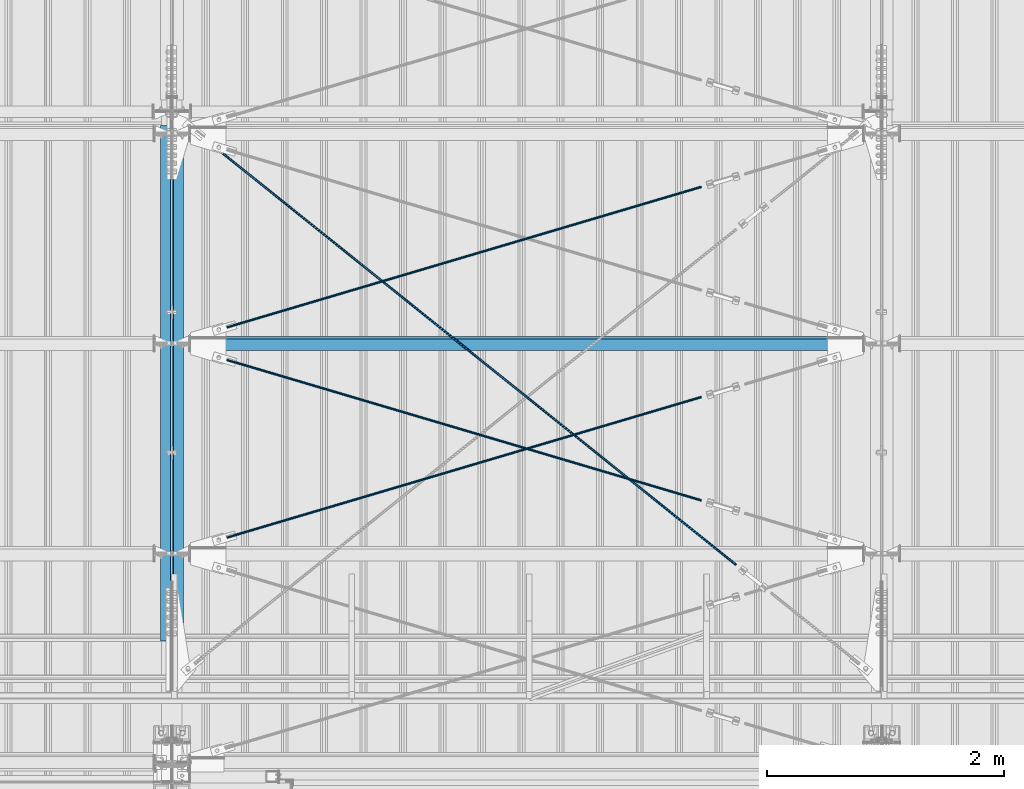
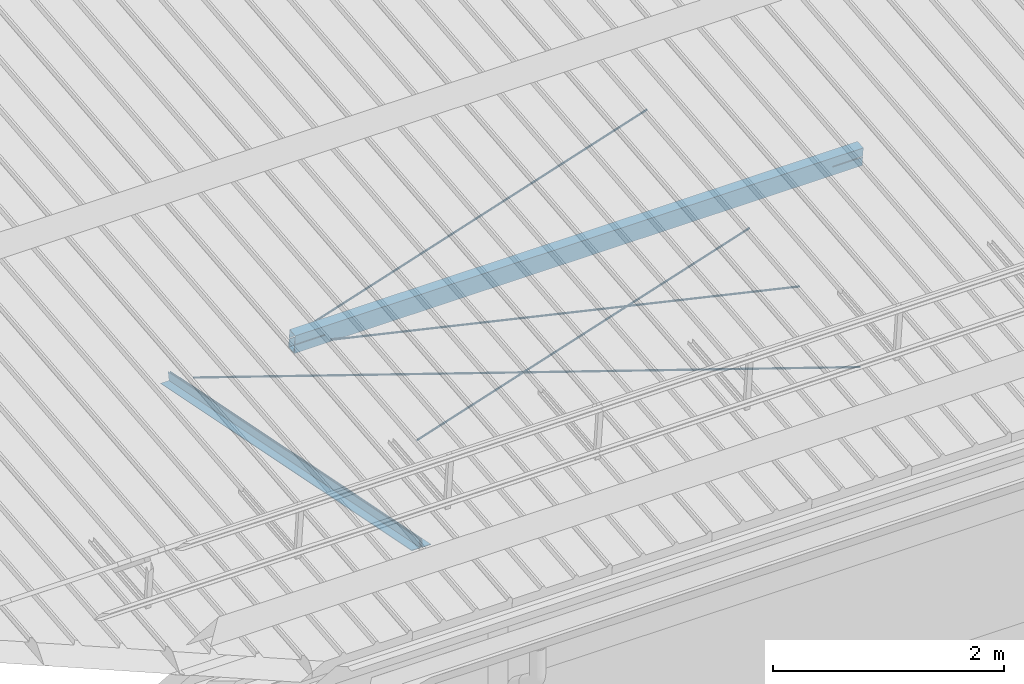
# One storey, part 274 of 709: 7 beams, 6 openings, 7 elements without a shape of their own.
"""IFC4 building model written with IfcOpenShell, lengths in millimetres."""

from ifc_helpers import new_model, si_unit, direction, frame, origin_with_axes, place, context, subcontext, project, spatial, line, indexed_curve, outline, extrude, polygons, material, element, aggregate, save


model = new_model("IFC4")

# Units and contexts
model_context = context("Model", 3, precision=0.2, world=origin_with_axes(), true_north=direction((0.0, 1.0)))
body_context = subcontext(model_context, "Body", "Model", "MODEL_VIEW")
reference_context = subcontext(model_context, "Reference", "Model", "MODEL_VIEW")
ifc_project = project(units=[si_unit("LENGTHUNIT", "METRE", prefix="MILLI"), si_unit("AREAUNIT", "SQUARE_METRE"), si_unit("VOLUMEUNIT", "CUBIC_METRE"), si_unit("MASSUNIT", "GRAM", prefix="KILO"), si_unit("TIMEUNIT", "SECOND"), si_unit("PLANEANGLEUNIT", "RADIAN"), si_unit("SOLIDANGLEUNIT", "STERADIAN"), si_unit("THERMODYNAMICTEMPERATUREUNIT", "DEGREE_CELSIUS"), si_unit("LUMINOUSINTENSITYUNIT", "LUMEN")], contexts=[model_context])

# Site, building, storey
site_placement = place(None, origin_with_axes())
site = spatial("IfcSite", under=ifc_project, at=site_placement, CompositionType="ELEMENT")
building_placement = place(site_placement, origin_with_axes())
building = spatial("IfcBuilding", under=site, at=building_placement, Name="Undefined", CompositionType="ELEMENT")
storey_placement = place(building_placement, origin_with_axes())
storey = spatial("IfcBuildingStorey", under=building, at=storey_placement, Name="Undefined", CompositionType="ELEMENT", Elevation=0.0)

# Assembly, beam
assembly_1_placement = place(storey_placement, frame((39949.0, 350.0596, 7109.99804), z_axis=(0.0, 0.1961161349, 0.9805806757), x_axis=(0.0, 0.9805806757, -0.1961161349)))
assembly_1 = element("IfcElementAssembly", 1, at=assembly_1_placement, inside=storey)
ifc_material_1 = material(Name="C345-5", Category="STEEL")
beam_1_placement = place(assembly_1_placement, origin_with_axes())
beam_1 = element("IfcBeam", 2, at=beam_1_placement, material=ifc_material_1, ObjectType="435", context=body_context, shape_type="Tessellation", body=[
    polygons([(873.96605, -45.0, -45.0), (873.96605, 45.0, -45.0), (5317.375, 45.0, -45.0), (5317.375, -45.0, -45.0), (873.96605, 45.0, -39.0), (5317.375, 45.0, -39.0), (873.96605, -39.0, -39.0), (5317.375, -39.0, -39.0), (873.96605, -39.0, 45.0), (5317.375, -39.0, 45.0), (873.96605, -45.0, 45.0), (5317.375, -45.0, 45.0)], [[[1, 2, 3, 4]], [[2, 5, 6, 3]], [[5, 7, 8, 6]], [[7, 9, 10, 8]], [[9, 11, 12, 10]], [[11, 1, 4, 12]], [[6, 8, 10, 12, 4, 3]], [[11, 9, 7, 5, 2, 1]]], closed=True),
])
aggregate(assembly_1, [beam_1])

assembly_2_placement = place(storey_placement, frame((40051.0, 5677.0596, 6044.59804), z_axis=(0.0, 0.1961161349, 0.9805806757), x_axis=(0.0, -0.9805806757, 0.1961161349)))
assembly_2 = element("IfcElementAssembly", 3, at=assembly_2_placement, inside=storey)
beam_2_placement = place(assembly_2_placement, origin_with_axes())
beam_2 = element("IfcBeam", 4, at=beam_2_placement, material=ifc_material_1, ObjectType="435", context=body_context, shape_type="Tessellation", body=[
    polygons([(115.12039, -45.0, -45.0), (115.12039, 45.0, -45.0), (4558.52934, 45.0, -45.0), (4558.52934, -45.0, -45.0), (115.12039, 45.0, -39.0), (4558.52934, 45.0, -39.0), (115.12039, -39.0, -39.0), (4558.52934, -39.0, -39.0), (115.12039, -39.0, 45.0), (4558.52934, -39.0, 45.0), (115.12039, -45.0, 45.0), (4558.52934, -45.0, 45.0)], [[[1, 2, 3, 4]], [[2, 5, 6, 3]], [[5, 7, 8, 6]], [[7, 9, 10, 8]], [[9, 11, 12, 10]], [[11, 1, 4, 12]], [[6, 8, 10, 12, 4, 3]], [[11, 9, 7, 5, 2, 1]]], closed=True),
])
aggregate(assembly_2, [beam_2])

# Assembly, beam, voiding feature
assembly_3_placement = place(storey_placement, frame((40000.0, 5665.09652, 5984.78262), z_axis=(-0.625451877, -0.7802627439, 1e-10), x_axis=(0.7742288439, -0.6206151549, 0.124123031)))
assembly_3 = element("IfcElementAssembly", 5, at=assembly_3_placement, inside=storey)
ifc_material_2 = material(Name="C355-5", Category="STEEL")
beam_3_placement = place(assembly_3_placement, origin_with_axes())
beam_3 = element("IfcBeam", 6, at=beam_3_placement, material=ifc_material_2, ObjectType="480", context=body_context, shape_type="Tessellation", body=[
    polygons([(6339.64669, 7.36121, 4.25), (6339.64669, 6.01041, 6.0104), (6339.64669, 4.25, 7.36121), (6339.64669, 2.19996, 8.21037), (6339.64669, 0.0, 8.5), (6339.64669, -2.19996, 8.21037), (6339.64669, -4.25, 7.36121), (6339.64669, -6.01041, 6.0104), (6339.64669, -7.36122, 4.25), (6339.64669, -8.21037, 2.19996), (6339.64669, -8.5, 0.0), (6339.64669, -8.21037, -2.19996), (6339.64669, -7.36122, -4.25), (6339.64669, -6.01041, -6.01041), (6339.64669, -4.25, -7.36122), (6339.64669, -2.19996, -8.21037), (6339.64669, 0.0, -8.5), (6339.64669, 2.19996, -8.21037), (6339.64669, 4.25, -7.36122), (6339.64669, 6.01041, -6.01041), (6339.64669, 7.36121, -4.25), (6339.64669, 8.21037, -2.19996), (6339.64669, 8.5, 0.0), (6339.64669, 8.21037, 2.19996), (6159.64669, 8.21037, 2.19996), (6159.64669, 7.36121, 4.25), (6159.64669, 6.01041, 6.0104), (6159.64669, 4.25, 7.36121), (6159.64669, 2.19996, 8.21037), (6159.64669, 0.0, 8.5), (6159.64669, -2.19996, 8.21037), (6159.64669, -4.25, 7.36121), (6159.64669, -6.01041, 6.0104), (6159.64669, -7.36122, 4.25), (6159.64669, -8.21037, 2.19996), (6159.64669, -8.5, 0.0), (6159.64669, -8.21037, -2.19996), (6159.64669, -7.36122, -4.25), (6159.64669, -6.01041, -6.01041), (6159.64669, -4.25, -7.36122), (6159.64669, -2.19996, -8.21037), (6159.64669, 0.0, -8.5), (6159.64669, 2.19996, -8.21037), (6159.64669, 4.25, -7.36122), (6159.64669, 6.01041, -6.01041), (6159.64669, 7.36121, -4.25), (6159.64669, 8.21037, -2.19996), (6159.64669, 8.5, 0.0), (6159.64669, 10.0, 0.0), (6159.64669, 9.65926, 2.58819), (6159.64669, 8.66025, 5.0), (6159.64669, 7.07107, 7.07107), (6159.64669, 5.0, 8.66025), (6159.64669, 2.58819, 9.65926), (6159.64669, 0.0, 10.0), (6159.64669, -2.58819, 9.65926), (6159.64669, -5.0, 8.66025), (6159.64669, -7.07107, 7.07107), (6159.64669, -8.66025, 5.0), (6159.64669, -9.65926, 2.58819), (6159.64669, -10.0, 0.0), (6159.64669, -9.65926, -2.58819), (6159.64669, -8.66025, -5.0), (6159.64669, -7.07107, -7.07107), (6159.64669, -5.0, -8.66025), (6159.64669, -2.58819, -9.65926), (6159.64669, 0.0, -10.0), (6159.64669, 2.58819, -9.65926), (6159.64669, 5.0, -8.66025), (6159.64669, 7.07107, -7.07107), (6159.64669, 8.66025, -5.0), (6159.64669, 9.65926, -2.58819), (259.57474, 2.58819, 9.65926), (259.57474, 5.0, 8.66025), (259.57474, 7.07107, 7.07107), (259.57474, 8.66025, 5.0), (259.57474, 9.65926, 2.58819), (259.57474, 10.0, 0.0), (259.57474, 9.65926, -2.58819), (259.57474, 8.66025, -5.0), (259.57474, 7.07107, -7.07107), (259.57474, 5.0, -8.66025), (259.57474, 2.58819, -9.65926), (259.57474, 0.0, -10.0), (259.57474, -2.58819, -9.65926), (259.57474, -5.0, -8.66025), (259.57474, -7.07107, -7.07107), (259.57474, -8.66025, -5.0), (259.57474, -9.65926, -2.58819), (259.57474, -10.0, 0.0), (259.57474, -9.65926, 2.58819), (259.57474, -8.66025, 5.0), (259.57474, -7.07107, 7.07107), (259.57474, -5.0, 8.66025), (259.57474, -2.58819, 9.65926), (259.57474, 0.0, 10.0)], [[[1, 2, 3, 4, 5, 6, 7, 8, 9, 10, 11, 12, 13, 14, 15, 16, 17, 18, 19, 20, 21, 22, 23, 24]], [[24, 25, 26, 1]], [[1, 26, 27, 2]], [[2, 27, 28, 3]], [[3, 28, 29, 4]], [[4, 29, 30, 5]], [[5, 30, 31, 6]], [[6, 31, 32, 7]], [[7, 32, 33, 8]], [[8, 33, 34, 9]], [[9, 34, 35, 10]], [[10, 35, 36, 11]], [[11, 36, 37, 12]], [[12, 37, 38, 13]], [[13, 38, 39, 14]], [[14, 39, 40, 15]], [[15, 40, 41, 16]], [[16, 41, 42, 17]], [[17, 42, 43, 18]], [[18, 43, 44, 19]], [[19, 44, 45, 20]], [[20, 45, 46, 21]], [[21, 46, 47, 22]], [[22, 47, 48, 23]], [[23, 48, 25, 24]], [[49, 50, 51, 52, 53, 54, 55, 56, 57, 58, 59, 60, 61, 62, 63, 64, 65, 66, 67, 68, 69, 70, 71, 72], [47, 46, 45, 44, 43, 42, 41, 40, 39, 38, 37, 36, 35, 34, 33, 32, 31, 30, 29, 28, 27, 26, 25, 48]], [[73, 74, 75, 76, 77, 78, 79, 80, 81, 82, 83, 84, 85, 86, 87, 88, 89, 90, 91, 92, 93, 94, 95, 96]], [[79, 78, 49, 72]], [[80, 79, 72, 71]], [[81, 80, 71, 70]], [[82, 81, 70, 69]], [[83, 82, 69, 68]], [[84, 83, 68, 67]], [[85, 84, 67, 66]], [[86, 85, 66, 65]], [[87, 86, 65, 64]], [[88, 87, 64, 63]], [[89, 88, 63, 62]], [[90, 89, 62, 61]], [[91, 90, 61, 60]], [[92, 91, 60, 59]], [[93, 92, 59, 58]], [[94, 93, 58, 57]], [[95, 94, 57, 56]], [[96, 95, 56, 55]], [[73, 96, 55, 54]], [[74, 73, 54, 53]], [[75, 74, 53, 52]], [[76, 75, 52, 51]], [[77, 76, 51, 50]], [[78, 77, 50, 49]]], closed=True),
])
voiding_feature_1_placement = place(beam_3_placement, frame((6339.64669, 0.0, 0.0), z_axis=(0.0, 1.0, 0.0), x_axis=(-1.0, 0.0, 0.0)))
element("IfcVoidingFeature", 7, at=voiding_feature_1_placement, cuts=beam_3, PredefinedType="HOLE", context=reference_context, identifier="Reference", shape_type="SolidModel", body=[
    extrude(outline(indexed_curve([(10.5, 0.0), (10.14222, 2.7176), (9.09327, 5.25), (7.42462, 7.42462), (5.25, 9.09327), (2.7176, 10.14222), (0.0, 10.5), (-2.7176, 10.14222), (-5.25, 9.09327), (-7.42462, 7.42462), (-9.09327, 5.25), (-10.14222, 2.7176), (-10.5, 0.0), (-10.14222, -2.7176), (-9.09327, -5.25), (-7.42462, -7.42462), (-5.25, -9.09327), (-2.7176, -10.14222), (0.0, -10.5), (2.7176, -10.14222), (5.25, -9.09327), (7.42462, -7.42462), (9.09327, -5.25), (10.14222, -2.7176)], segments=[line(1, 2, 3, 4, 5, 6, 7, 8, 9, 10, 11, 12, 13, 14, 15, 16, 17, 18, 19, 20, 21, 22, 23, 24, 1)])), frame((0.0, 0.0, 0.0), z_axis=(-1.0, 0.0, 0.0), x_axis=(0.0, 0.0, 1.0)), (0.0, 0.0, -1.0), 180.0),
])
aggregate(assembly_3, [beam_3])

assembly_4_placement = place(storey_placement, frame((40000.0, 1935.85409, 7330.08943), z_axis=(0.2852311229, -0.9537021177, -0.0953702118), x_axis=(0.9584587662, 0.2838155751, 0.028381558)))
assembly_4 = element("IfcElementAssembly", 8, at=assembly_4_placement, inside=storey)
beam_4_placement = place(assembly_4_placement, origin_with_axes())
beam_4 = element("IfcBeam", 9, at=beam_4_placement, material=ifc_material_2, ObjectType="570", context=body_context, shape_type="Tessellation", body=[
    polygons([(4850.05021, 7.36122, 4.25), (4850.05021, 6.01041, 6.01041), (4850.05021, 4.25, 7.36121), (4850.05021, 2.19996, 8.21037), (4850.05021, 0.0, 8.5), (4850.05021, -2.19996, 8.21037), (4850.05021, -4.25, 7.36121), (4850.05021, -6.01041, 6.01041), (4850.05021, -7.36121, 4.25), (4850.05021, -8.21037, 2.19996), (4850.05021, -8.5, 0.0), (4850.05021, -8.21037, -2.19996), (4850.05021, -7.36121, -4.25), (4850.05021, -6.01041, -6.01041), (4850.05021, -4.25, -7.36122), (4850.05021, -2.19996, -8.21037), (4850.05021, 0.0, -8.5), (4850.05021, 2.19996, -8.21037), (4850.05021, 4.25, -7.36122), (4850.05021, 6.01041, -6.01041), (4850.05021, 7.36122, -4.25), (4850.05021, 8.21037, -2.19996), (4850.05021, 8.5, 0.0), (4850.05021, 8.21037, 2.19996), (4670.05021, 8.21037, 2.19996), (4670.05021, 7.36122, 4.25), (4670.05021, 6.01041, 6.01041), (4670.05021, 4.25, 7.36121), (4670.05021, 2.19996, 8.21037), (4670.05021, 0.0, 8.5), (4670.05021, -2.19996, 8.21037), (4670.05021, -4.25, 7.36121), (4670.05021, -6.01041, 6.01041), (4670.05021, -7.36121, 4.25), (4670.05021, -8.21037, 2.19996), (4670.05021, -8.5, 0.0), (4670.05021, -8.21037, -2.19996), (4670.05021, -7.36121, -4.25), (4670.05021, -6.01041, -6.01041), (4670.05021, -4.25, -7.36122), (4670.05021, -2.19996, -8.21037), (4670.05021, 0.0, -8.5), (4670.05021, 2.19996, -8.21037), (4670.05021, 4.25, -7.36122), (4670.05021, 6.01041, -6.01041), (4670.05021, 7.36122, -4.25), (4670.05021, 8.21037, -2.19996), (4670.05021, 8.5, 0.0), (4670.05021, 10.0, 0.0), (4670.05021, 9.65926, 2.58819), (4670.05021, 8.66025, 5.0), (4670.05021, 7.07107, 7.07107), (4670.05021, 5.0, 8.66025), (4670.05021, 2.58819, 9.65926), (4670.05021, 0.0, 10.0), (4670.05021, -2.58819, 9.65926), (4670.05021, -5.0, 8.66025), (4670.05021, -7.07107, 7.07107), (4670.05021, -8.66025, 5.0), (4670.05021, -9.65926, 2.58819), (4670.05021, -10.0, 0.0), (4670.05021, -9.65926, -2.58819), (4670.05021, -8.66025, -5.0), (4670.05021, -7.07107, -7.07107), (4670.05021, -5.0, -8.66025), (4670.05021, -2.58819, -9.65926), (4670.05021, 0.0, -10.0), (4670.05021, 2.58819, -9.65926), (4670.05021, 5.0, -8.66025), (4670.05021, 7.07107, -7.07107), (4670.05021, 8.66025, -5.0), (4670.05021, 9.65926, -2.58819), (483.0251, 2.58819, 9.65926), (483.0251, 5.0, 8.66025), (483.0251, 7.07107, 7.07107), (483.0251, 8.66025, 5.0), (483.0251, 9.65926, 2.58819), (483.0251, 10.0, 0.0), (483.0251, 9.65926, -2.58819), (483.0251, 8.66025, -5.0), (483.0251, 7.07107, -7.07107), (483.0251, 5.0, -8.66025), (483.0251, 2.58819, -9.65926), (483.0251, 0.0, -10.0), (483.0251, -2.58819, -9.65926), (483.0251, -5.0, -8.66025), (483.0251, -7.07107, -7.07107), (483.0251, -8.66025, -5.0), (483.0251, -9.65926, -2.58819), (483.0251, -10.0, 0.0), (483.0251, -9.65926, 2.58819), (483.0251, -8.66025, 5.0), (483.0251, -7.07107, 7.07107), (483.0251, -5.0, 8.66025), (483.0251, -2.58819, 9.65926), (483.0251, 0.0, 10.0)], [[[1, 2, 3, 4, 5, 6, 7, 8, 9, 10, 11, 12, 13, 14, 15, 16, 17, 18, 19, 20, 21, 22, 23, 24]], [[24, 25, 26, 1]], [[1, 26, 27, 2]], [[2, 27, 28, 3]], [[3, 28, 29, 4]], [[4, 29, 30, 5]], [[5, 30, 31, 6]], [[6, 31, 32, 7]], [[7, 32, 33, 8]], [[8, 33, 34, 9]], [[9, 34, 35, 10]], [[10, 35, 36, 11]], [[11, 36, 37, 12]], [[12, 37, 38, 13]], [[13, 38, 39, 14]], [[14, 39, 40, 15]], [[15, 40, 41, 16]], [[16, 41, 42, 17]], [[17, 42, 43, 18]], [[18, 43, 44, 19]], [[19, 44, 45, 20]], [[20, 45, 46, 21]], [[21, 46, 47, 22]], [[22, 47, 48, 23]], [[23, 48, 25, 24]], [[49, 50, 51, 52, 53, 54, 55, 56, 57, 58, 59, 60, 61, 62, 63, 64, 65, 66, 67, 68, 69, 70, 71, 72], [47, 46, 45, 44, 43, 42, 41, 40, 39, 38, 37, 36, 35, 34, 33, 32, 31, 30, 29, 28, 27, 26, 25, 48]], [[73, 74, 75, 76, 77, 78, 79, 80, 81, 82, 83, 84, 85, 86, 87, 88, 89, 90, 91, 92, 93, 94, 95, 96]], [[79, 78, 49, 72]], [[80, 79, 72, 71]], [[81, 80, 71, 70]], [[82, 81, 70, 69]], [[83, 82, 69, 68]], [[84, 83, 68, 67]], [[85, 84, 67, 66]], [[86, 85, 66, 65]], [[87, 86, 65, 64]], [[88, 87, 64, 63]], [[89, 88, 63, 62]], [[90, 89, 62, 61]], [[91, 90, 61, 60]], [[92, 91, 60, 59]], [[93, 92, 59, 58]], [[94, 93, 58, 57]], [[95, 94, 57, 56]], [[96, 95, 56, 55]], [[73, 96, 55, 54]], [[74, 73, 54, 53]], [[75, 74, 53, 52]], [[76, 75, 52, 51]], [[77, 76, 51, 50]], [[78, 77, 50, 49]]], closed=True),
])
voiding_feature_2_placement = place(beam_4_placement, frame((4850.05021, 0.0, 0.0), z_axis=(0.0, 1.0, 0.0), x_axis=(-1.0, 0.0, 0.0)))
element("IfcVoidingFeature", 10, at=voiding_feature_2_placement, cuts=beam_4, PredefinedType="HOLE", context=reference_context, identifier="Reference", shape_type="SolidModel", body=[
    extrude(outline(indexed_curve([(10.5, 0.0), (10.14222, 2.7176), (9.09327, 5.25), (7.42462, 7.42462), (5.25, 9.09327), (2.7176, 10.14222), (0.0, 10.5), (-2.7176, 10.14222), (-5.25, 9.09327), (-7.42462, 7.42462), (-9.09327, 5.25), (-10.14222, 2.7176), (-10.5, 0.0), (-10.14222, -2.7176), (-9.09327, -5.25), (-7.42462, -7.42462), (-5.25, -9.09327), (-2.7176, -10.14222), (0.0, -10.5), (2.7176, -10.14222), (5.25, -9.09327), (7.42462, -7.42462), (9.09327, -5.25), (10.14222, -2.7176)], segments=[line(1, 2, 3, 4, 5, 6, 7, 8, 9, 10, 11, 12, 13, 14, 15, 16, 17, 18, 19, 20, 21, 22, 23, 24, 1)])), frame((0.0, 0.0, 0.0), z_axis=(-1.0, 0.0, 0.0), x_axis=(0.0, 0.0, 1.0)), (0.0, 0.0, -1.0), 180.0),
])
aggregate(assembly_4, [beam_4])

assembly_5_placement = place(storey_placement, frame((40000.0, 3712.55385, 7507.7594), z_axis=(-0.2852311229, -0.9537021177, -0.0953702118), x_axis=(0.9584587662, -0.2838155751, -0.028381558)))
assembly_5 = element("IfcElementAssembly", 11, at=assembly_5_placement, inside=storey)
beam_5_placement = place(assembly_5_placement, origin_with_axes())
beam_5 = element("IfcBeam", 12, at=beam_5_placement, material=ifc_material_2, ObjectType="570", context=body_context, shape_type="Tessellation", body=[
    polygons([(4850.05021, 7.36122, 4.25), (4850.05021, 6.01041, 6.01041), (4850.05021, 4.25, 7.36121), (4850.05021, 2.19996, 8.21037), (4850.05021, 0.0, 8.5), (4850.05021, -2.19996, 8.21037), (4850.05021, -4.25, 7.36121), (4850.05021, -6.01041, 6.01041), (4850.05021, -7.36121, 4.25), (4850.05021, -8.21037, 2.19996), (4850.05021, -8.5, 0.0), (4850.05021, -8.21037, -2.19996), (4850.05021, -7.36121, -4.25), (4850.05021, -6.01041, -6.01041), (4850.05021, -4.25, -7.36122), (4850.05021, -2.19996, -8.21037), (4850.05021, 0.0, -8.5), (4850.05021, 2.19996, -8.21037), (4850.05021, 4.25, -7.36122), (4850.05021, 6.01041, -6.01041), (4850.05021, 7.36122, -4.25), (4850.05021, 8.21037, -2.19996), (4850.05021, 8.5, 0.0), (4850.05021, 8.21037, 2.19996), (4670.05021, 8.21037, 2.19996), (4670.05021, 7.36122, 4.25), (4670.05021, 6.01041, 6.01041), (4670.05021, 4.25, 7.36121), (4670.05021, 2.19996, 8.21037), (4670.05021, 0.0, 8.5), (4670.05021, -2.19996, 8.21037), (4670.05021, -4.25, 7.36121), (4670.05021, -6.01041, 6.01041), (4670.05021, -7.36121, 4.25), (4670.05021, -8.21037, 2.19996), (4670.05021, -8.5, 0.0), (4670.05021, -8.21037, -2.19996), (4670.05021, -7.36121, -4.25), (4670.05021, -6.01041, -6.01041), (4670.05021, -4.25, -7.36122), (4670.05021, -2.19996, -8.21037), (4670.05021, 0.0, -8.5), (4670.05021, 2.19996, -8.21037), (4670.05021, 4.25, -7.36122), (4670.05021, 6.01041, -6.01041), (4670.05021, 7.36122, -4.25), (4670.05021, 8.21037, -2.19996), (4670.05021, 8.5, 0.0), (4670.05021, 10.0, 0.0), (4670.05021, 9.65926, 2.58819), (4670.05021, 8.66025, 5.0), (4670.05021, 7.07107, 7.07107), (4670.05021, 5.0, 8.66025), (4670.05021, 2.58819, 9.65926), (4670.05021, 0.0, 10.0), (4670.05021, -2.58819, 9.65926), (4670.05021, -5.0, 8.66025), (4670.05021, -7.07107, 7.07107), (4670.05021, -8.66025, 5.0), (4670.05021, -9.65926, 2.58819), (4670.05021, -10.0, 0.0), (4670.05021, -9.65926, -2.58819), (4670.05021, -8.66025, -5.0), (4670.05021, -7.07107, -7.07107), (4670.05021, -5.0, -8.66025), (4670.05021, -2.58819, -9.65926), (4670.05021, 0.0, -10.0), (4670.05021, 2.58819, -9.65926), (4670.05021, 5.0, -8.66025), (4670.05021, 7.07107, -7.07107), (4670.05021, 8.66025, -5.0), (4670.05021, 9.65926, -2.58819), (483.0251, 2.58819, 9.65926), (483.0251, 5.0, 8.66025), (483.0251, 7.07107, 7.07107), (483.0251, 8.66025, 5.0), (483.0251, 9.65926, 2.58819), (483.0251, 10.0, 0.0), (483.0251, 9.65926, -2.58819), (483.0251, 8.66025, -5.0), (483.0251, 7.07107, -7.07107), (483.0251, 5.0, -8.66025), (483.0251, 2.58819, -9.65926), (483.0251, 0.0, -10.0), (483.0251, -2.58819, -9.65926), (483.0251, -5.0, -8.66025), (483.0251, -7.07107, -7.07107), (483.0251, -8.66025, -5.0), (483.0251, -9.65926, -2.58819), (483.0251, -10.0, 0.0), (483.0251, -9.65926, 2.58819), (483.0251, -8.66025, 5.0), (483.0251, -7.07107, 7.07107), (483.0251, -5.0, 8.66025), (483.0251, -2.58819, 9.65926), (483.0251, 0.0, 10.0)], [[[1, 2, 3, 4, 5, 6, 7, 8, 9, 10, 11, 12, 13, 14, 15, 16, 17, 18, 19, 20, 21, 22, 23, 24]], [[24, 25, 26, 1]], [[1, 26, 27, 2]], [[2, 27, 28, 3]], [[3, 28, 29, 4]], [[4, 29, 30, 5]], [[5, 30, 31, 6]], [[6, 31, 32, 7]], [[7, 32, 33, 8]], [[8, 33, 34, 9]], [[9, 34, 35, 10]], [[10, 35, 36, 11]], [[11, 36, 37, 12]], [[12, 37, 38, 13]], [[13, 38, 39, 14]], [[14, 39, 40, 15]], [[15, 40, 41, 16]], [[16, 41, 42, 17]], [[17, 42, 43, 18]], [[18, 43, 44, 19]], [[19, 44, 45, 20]], [[20, 45, 46, 21]], [[21, 46, 47, 22]], [[22, 47, 48, 23]], [[23, 48, 25, 24]], [[49, 50, 51, 52, 53, 54, 55, 56, 57, 58, 59, 60, 61, 62, 63, 64, 65, 66, 67, 68, 69, 70, 71, 72], [47, 46, 45, 44, 43, 42, 41, 40, 39, 38, 37, 36, 35, 34, 33, 32, 31, 30, 29, 28, 27, 26, 25, 48]], [[73, 74, 75, 76, 77, 78, 79, 80, 81, 82, 83, 84, 85, 86, 87, 88, 89, 90, 91, 92, 93, 94, 95, 96]], [[79, 78, 49, 72]], [[80, 79, 72, 71]], [[81, 80, 71, 70]], [[82, 81, 70, 69]], [[83, 82, 69, 68]], [[84, 83, 68, 67]], [[85, 84, 67, 66]], [[86, 85, 66, 65]], [[87, 86, 65, 64]], [[88, 87, 64, 63]], [[89, 88, 63, 62]], [[90, 89, 62, 61]], [[91, 90, 61, 60]], [[92, 91, 60, 59]], [[93, 92, 59, 58]], [[94, 93, 58, 57]], [[95, 94, 57, 56]], [[96, 95, 56, 55]], [[73, 96, 55, 54]], [[74, 73, 54, 53]], [[75, 74, 53, 52]], [[76, 75, 52, 51]], [[77, 76, 51, 50]], [[78, 77, 50, 49]]], closed=True),
])
voiding_feature_3_placement = place(beam_5_placement, frame((4850.05021, 0.0, 0.0), z_axis=(0.0, 1.0, 0.0), x_axis=(-1.0, 0.0, 0.0)))
element("IfcVoidingFeature", 13, at=voiding_feature_3_placement, cuts=beam_5, PredefinedType="HOLE", context=reference_context, identifier="Reference", shape_type="SolidModel", body=[
    extrude(outline(indexed_curve([(10.5, 0.0), (10.14222, 2.7176), (9.09327, 5.25), (7.42462, 7.42462), (5.25, 9.09327), (2.7176, 10.14222), (0.0, 10.5), (-2.7176, 10.14222), (-5.25, 9.09327), (-7.42462, 7.42462), (-9.09327, 5.25), (-10.14222, 2.7176), (-10.5, 0.0), (-10.14222, -2.7176), (-9.09327, -5.25), (-7.42462, -7.42462), (-5.25, -9.09327), (-2.7176, -10.14222), (0.0, -10.5), (2.7176, -10.14222), (5.25, -9.09327), (7.42462, -7.42462), (9.09327, -5.25), (10.14222, -2.7176)], segments=[line(1, 2, 3, 4, 5, 6, 7, 8, 9, 10, 11, 12, 13, 14, 15, 16, 17, 18, 19, 20, 21, 22, 23, 24, 1)])), frame((0.0, 0.0, 0.0), z_axis=(-1.0, 0.0, 0.0), x_axis=(0.0, 0.0, 1.0)), (0.0, 0.0, -1.0), 180.0),
])
aggregate(assembly_5, [beam_5])

assembly_6_placement = place(storey_placement, frame((40000.0, 3712.55385, 7507.7594), z_axis=(0.2852311229, -0.9537021177, -0.0953702118), x_axis=(0.9584587662, 0.2838155751, 0.028381558)))
assembly_6 = element("IfcElementAssembly", 14, at=assembly_6_placement, inside=storey)
beam_6_placement = place(assembly_6_placement, origin_with_axes())
beam_6 = element("IfcBeam", 15, at=beam_6_placement, material=ifc_material_2, ObjectType="570", context=body_context, shape_type="Tessellation", body=[
    polygons([(4850.05021, 7.36122, 4.25), (4850.05021, 6.01041, 6.01041), (4850.05021, 4.25, 7.36121), (4850.05021, 2.19996, 8.21037), (4850.05021, 0.0, 8.5), (4850.05021, -2.19996, 8.21037), (4850.05021, -4.25, 7.36121), (4850.05021, -6.01041, 6.01041), (4850.05021, -7.36121, 4.25), (4850.05021, -8.21037, 2.19996), (4850.05021, -8.5, 0.0), (4850.05021, -8.21037, -2.19996), (4850.05021, -7.36121, -4.25), (4850.05021, -6.01041, -6.01041), (4850.05021, -4.25, -7.36122), (4850.05021, -2.19996, -8.21037), (4850.05021, 0.0, -8.5), (4850.05021, 2.19996, -8.21037), (4850.05021, 4.25, -7.36122), (4850.05021, 6.01041, -6.01041), (4850.05021, 7.36122, -4.25), (4850.05021, 8.21037, -2.19996), (4850.05021, 8.5, 0.0), (4850.05021, 8.21037, 2.19996), (4670.05021, 8.21037, 2.19996), (4670.05021, 7.36122, 4.25), (4670.05021, 6.01041, 6.01041), (4670.05021, 4.25, 7.36121), (4670.05021, 2.19996, 8.21037), (4670.05021, 0.0, 8.5), (4670.05021, -2.19996, 8.21037), (4670.05021, -4.25, 7.36121), (4670.05021, -6.01041, 6.01041), (4670.05021, -7.36121, 4.25), (4670.05021, -8.21037, 2.19996), (4670.05021, -8.5, 0.0), (4670.05021, -8.21037, -2.19996), (4670.05021, -7.36121, -4.25), (4670.05021, -6.01041, -6.01041), (4670.05021, -4.25, -7.36122), (4670.05021, -2.19996, -8.21037), (4670.05021, 0.0, -8.5), (4670.05021, 2.19996, -8.21037), (4670.05021, 4.25, -7.36122), (4670.05021, 6.01041, -6.01041), (4670.05021, 7.36122, -4.25), (4670.05021, 8.21037, -2.19996), (4670.05021, 8.5, 0.0), (4670.05021, 10.0, 0.0), (4670.05021, 9.65926, 2.58819), (4670.05021, 8.66025, 5.0), (4670.05021, 7.07107, 7.07107), (4670.05021, 5.0, 8.66025), (4670.05021, 2.58819, 9.65926), (4670.05021, 0.0, 10.0), (4670.05021, -2.58819, 9.65926), (4670.05021, -5.0, 8.66025), (4670.05021, -7.07107, 7.07107), (4670.05021, -8.66025, 5.0), (4670.05021, -9.65926, 2.58819), (4670.05021, -10.0, 0.0), (4670.05021, -9.65926, -2.58819), (4670.05021, -8.66025, -5.0), (4670.05021, -7.07107, -7.07107), (4670.05021, -5.0, -8.66025), (4670.05021, -2.58819, -9.65926), (4670.05021, 0.0, -10.0), (4670.05021, 2.58819, -9.65926), (4670.05021, 5.0, -8.66025), (4670.05021, 7.07107, -7.07107), (4670.05021, 8.66025, -5.0), (4670.05021, 9.65926, -2.58819), (483.0251, 2.58819, 9.65926), (483.0251, 5.0, 8.66025), (483.0251, 7.07107, 7.07107), (483.0251, 8.66025, 5.0), (483.0251, 9.65926, 2.58819), (483.0251, 10.0, 0.0), (483.0251, 9.65926, -2.58819), (483.0251, 8.66025, -5.0), (483.0251, 7.07107, -7.07107), (483.0251, 5.0, -8.66025), (483.0251, 2.58819, -9.65926), (483.0251, 0.0, -10.0), (483.0251, -2.58819, -9.65926), (483.0251, -5.0, -8.66025), (483.0251, -7.07107, -7.07107), (483.0251, -8.66025, -5.0), (483.0251, -9.65926, -2.58819), (483.0251, -10.0, 0.0), (483.0251, -9.65926, 2.58819), (483.0251, -8.66025, 5.0), (483.0251, -7.07107, 7.07107), (483.0251, -5.0, 8.66025), (483.0251, -2.58819, 9.65926), (483.0251, 0.0, 10.0)], [[[1, 2, 3, 4, 5, 6, 7, 8, 9, 10, 11, 12, 13, 14, 15, 16, 17, 18, 19, 20, 21, 22, 23, 24]], [[24, 25, 26, 1]], [[1, 26, 27, 2]], [[2, 27, 28, 3]], [[3, 28, 29, 4]], [[4, 29, 30, 5]], [[5, 30, 31, 6]], [[6, 31, 32, 7]], [[7, 32, 33, 8]], [[8, 33, 34, 9]], [[9, 34, 35, 10]], [[10, 35, 36, 11]], [[11, 36, 37, 12]], [[12, 37, 38, 13]], [[13, 38, 39, 14]], [[14, 39, 40, 15]], [[15, 40, 41, 16]], [[16, 41, 42, 17]], [[17, 42, 43, 18]], [[18, 43, 44, 19]], [[19, 44, 45, 20]], [[20, 45, 46, 21]], [[21, 46, 47, 22]], [[22, 47, 48, 23]], [[23, 48, 25, 24]], [[49, 50, 51, 52, 53, 54, 55, 56, 57, 58, 59, 60, 61, 62, 63, 64, 65, 66, 67, 68, 69, 70, 71, 72], [47, 46, 45, 44, 43, 42, 41, 40, 39, 38, 37, 36, 35, 34, 33, 32, 31, 30, 29, 28, 27, 26, 25, 48]], [[73, 74, 75, 76, 77, 78, 79, 80, 81, 82, 83, 84, 85, 86, 87, 88, 89, 90, 91, 92, 93, 94, 95, 96]], [[79, 78, 49, 72]], [[80, 79, 72, 71]], [[81, 80, 71, 70]], [[82, 81, 70, 69]], [[83, 82, 69, 68]], [[84, 83, 68, 67]], [[85, 84, 67, 66]], [[86, 85, 66, 65]], [[87, 86, 65, 64]], [[88, 87, 64, 63]], [[89, 88, 63, 62]], [[90, 89, 62, 61]], [[91, 90, 61, 60]], [[92, 91, 60, 59]], [[93, 92, 59, 58]], [[94, 93, 58, 57]], [[95, 94, 57, 56]], [[96, 95, 56, 55]], [[73, 96, 55, 54]], [[74, 73, 54, 53]], [[75, 74, 53, 52]], [[76, 75, 52, 51]], [[77, 76, 51, 50]], [[78, 77, 50, 49]]], closed=True),
])
voiding_feature_4_placement = place(beam_6_placement, frame((4850.05021, 0.0, 0.0), z_axis=(0.0, 1.0, 0.0), x_axis=(-1.0, 0.0, 0.0)))
element("IfcVoidingFeature", 16, at=voiding_feature_4_placement, cuts=beam_6, PredefinedType="HOLE", context=reference_context, identifier="Reference", shape_type="SolidModel", body=[
    extrude(outline(indexed_curve([(10.5, 0.0), (10.14222, 2.7176), (9.09327, 5.25), (7.42462, 7.42462), (5.25, 9.09327), (2.7176, 10.14222), (0.0, 10.5), (-2.7176, 10.14222), (-5.25, 9.09327), (-7.42462, 7.42462), (-9.09327, 5.25), (-10.14222, 2.7176), (-10.5, 0.0), (-10.14222, -2.7176), (-9.09327, -5.25), (-7.42462, -7.42462), (-5.25, -9.09327), (-2.7176, -10.14222), (0.0, -10.5), (2.7176, -10.14222), (5.25, -9.09327), (7.42462, -7.42462), (9.09327, -5.25), (10.14222, -2.7176)], segments=[line(1, 2, 3, 4, 5, 6, 7, 8, 9, 10, 11, 12, 13, 14, 15, 16, 17, 18, 19, 20, 21, 22, 23, 24, 1)])), frame((0.0, 0.0, 0.0), z_axis=(-1.0, 0.0, 0.0), x_axis=(0.0, 0.0, 1.0)), (0.0, 0.0, -1.0), 180.0),
])
aggregate(assembly_6, [beam_6])

# Assembly, beam, voiding features
assembly_7_placement = place(storey_placement, frame((40000.0, 3713.34988, 7499.7991), z_axis=(0.0, 0.9950371902, 0.099503719), x_axis=(1.0, 0.0, 0.0)))
assembly_7 = element("IfcElementAssembly", 17, at=assembly_7_placement, inside=storey)
ifc_material_3 = material(Name="C355", Category="STEEL")
beam_7_placement = place(assembly_7_placement, origin_with_axes())
beam_7 = element("IfcBeam", 18, at=beam_7_placement, material=ifc_material_3, ObjectType="566", context=body_context, shape_type="Tessellation", body=[
    polygons([(5845.0, -5.0, 50.0), (5845.0, -5.0, 46.0), (5543.37414, -5.0, 46.0), (5543.37414, -5.0, 50.0), (5543.37414, 5.0, 46.0), (5543.37414, 5.0, 50.0), (5845.00055, 5.0, 50.0), (5845.0, 5.0, 46.0), (5845.0, -5.0, -46.0), (5845.0, -5.0, -50.0), (5543.37413, -5.0, -50.0), (5543.37413, -5.0, -46.0), (5543.37413, 5.0, -50.0), (5543.37413, 5.0, -46.0), (5845.00055, 5.0, -46.0), (5845.0, 5.0, -50.0), (155.0, 96.0, 46.0), (155.0, 96.0, -46.0), (5845.0, 96.0, -46.0), (5845.0, 96.0, 46.0), (5845.0, -96.0, 46.0), (155.0, -96.0, 46.0), (155.0, -5.0, 46.0), (456.62587, -5.0, 46.0), (456.62587, 5.0, 46.0), (155.0, 5.0, 46.0), (155.0, -96.0, -46.0), (5845.0, -96.0, -46.0), (155.0, 5.0, -46.0), (155.0, 5.0, -50.0), (456.62587, 5.0, -50.0), (456.62587, 5.0, -46.0), (456.62587, -5.0, -50.0), (456.62587, -5.0, -46.0), (155.0, -5.0, -50.0), (155.0, -5.0, -46.0), (155.0, -100.0, -50.0), (155.0, -100.0, 50.0), (155.0, -5.0, 50.0), (456.62587, -5.0, 50.0), (456.62587, 5.0, 50.0), (155.0, 5.0, 50.0), (155.0, 100.0, 50.0), (155.0, 100.0, -50.0), (5845.0, 100.0, 50.0), (5845.0, 100.0, -50.0), (5845.0, -100.0, -50.0), (5845.0, -100.0, 50.0)], [[[1, 2, 3, 4]], [[4, 3, 5, 6]], [[7, 6, 5, 8]], [[9, 10, 11, 12]], [[12, 11, 13, 14]], [[15, 14, 13, 16]], [[17, 18, 19, 20]], [[3, 2, 21, 22, 23, 24, 25, 26, 17, 20, 8, 5]], [[27, 22, 21, 28]], [[29, 30, 31, 32]], [[32, 31, 33, 34]], [[34, 33, 35, 36]], [[22, 27, 36, 35, 37, 38, 39, 23]], [[40, 24, 23, 39]], [[41, 25, 24, 40]], [[42, 26, 25, 41]], [[43, 44, 30, 29, 18, 17, 26, 42]], [[44, 43, 45, 46]], [[20, 19, 15, 16, 46, 45, 7, 8]], [[11, 10, 47, 37, 35, 33, 31, 30, 44, 46, 16, 13]], [[38, 37, 47, 48]], [[45, 43, 42, 41, 40, 39, 38, 48, 1, 4, 6, 7]], [[48, 47, 10, 9, 28, 21, 2, 1]], [[19, 18, 29, 32, 34, 36, 27, 28, 9, 12, 14, 15]]], closed=True),
])
voiding_feature_5_placement = place(beam_7_placement, frame((154.99945, 0.0, 93.07721), z_axis=(0.0, -1.0, 0.0), x_axis=(0.0, 0.0, -1.0)))
element("IfcVoidingFeature", 19, at=voiding_feature_5_placement, cuts=beam_7, Name="PLATE", PredefinedType="HOLE", context=reference_context, identifier="Reference", shape_type="SolidModel", body=[
    extrude(outline(indexed_curve([(0.0, 0.0), (186.15442, 0.0), (268.27702, 275.95562), (182.01573, 301.62642), (4.13868, 301.62642), (-82.1226, 275.95562)], segments=[line(1, 2, 3, 4, 5, 6, 1)])), frame((0.0, 0.0, 5.0), z_axis=(0.0, 0.0, 1.0), x_axis=(1.0, 0.0, 0.0)), (0.0, 0.0, -1.0), 10.0),
])
voiding_feature_6_placement = place(beam_7_placement, frame((5845.00055, 0.0, -93.07721), z_axis=(0.0, -1.0, 0.0), x_axis=(0.0, 0.0, 1.0)))
element("IfcVoidingFeature", 20, at=voiding_feature_6_placement, cuts=beam_7, Name="PLATE", PredefinedType="HOLE", context=reference_context, identifier="Reference", shape_type="SolidModel", body=[
    extrude(outline(indexed_curve([(0.0, 0.0), (186.15442, 0.0), (268.27702, 275.95562), (182.01573, 301.62642), (4.13868, 301.62642), (-82.1226, 275.95562)], segments=[line(1, 2, 3, 4, 5, 6, 1)])), frame((0.0, 0.0, 5.0), z_axis=(0.0, 0.0, 1.0), x_axis=(1.0, 0.0, 0.0)), (0.0, 0.0, -1.0), 10.0),
])
aggregate(assembly_7, [beam_7])

save(model, "model.ifc")
